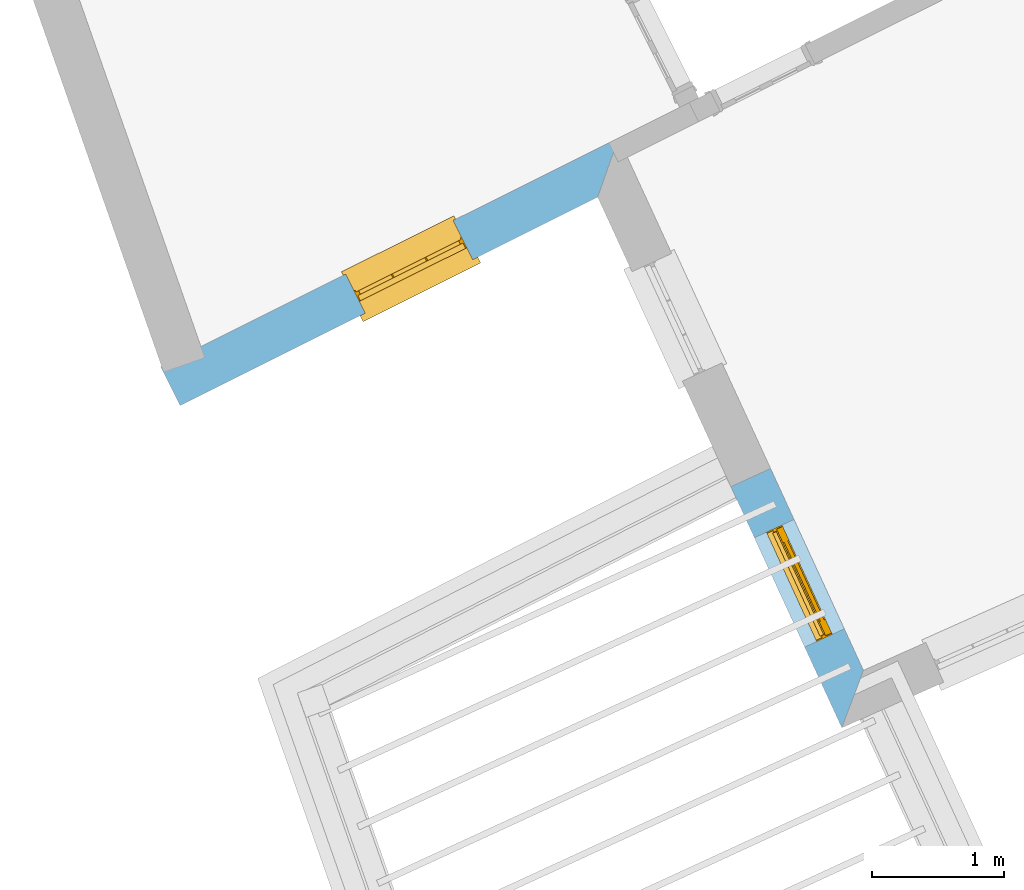
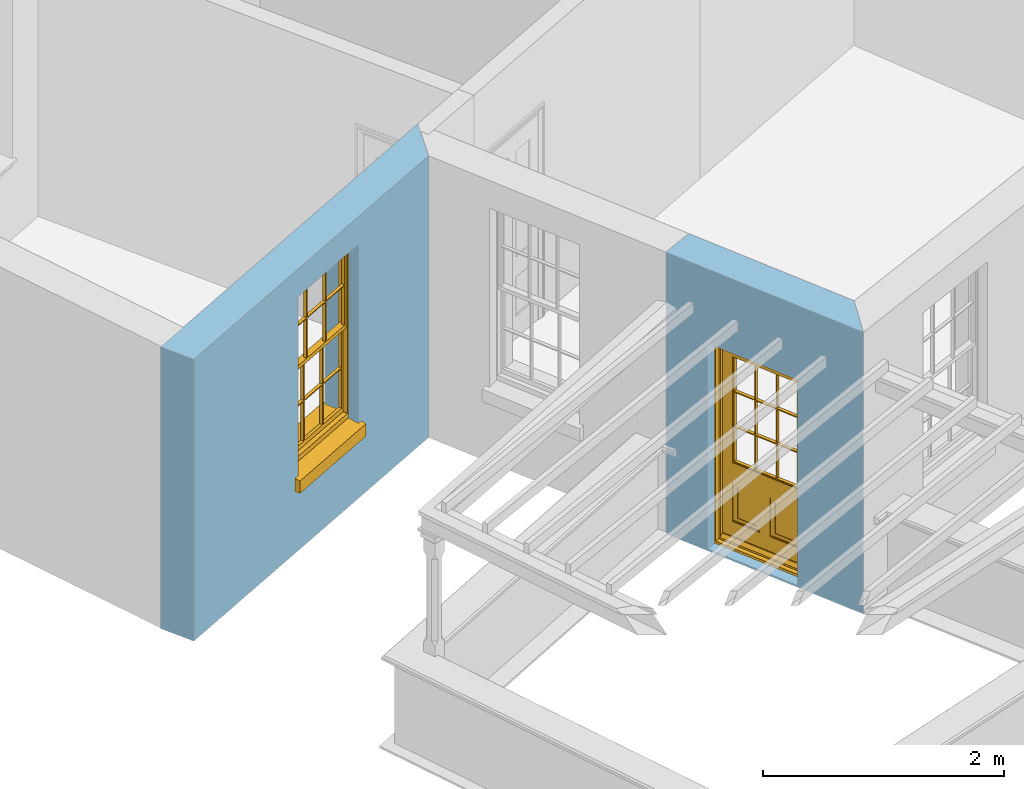
# One storey, part 2 of 9: 1 door, 1 window, 2 openings, plus 2 elements that do not belong to this part.
"""IFC2X3 building model written with IfcOpenShell, lengths in metres."""

from ifc_helpers import new_model, si_unit, frame, origin, place, context, subcontext, project, spatial, polyline, outline, extrude, faceted_brep, material, layer, layer_set, layer_usage, element, fill, save


model = new_model("IFC2X3")

# Units and contexts
model_context = context("Model", 3, world=origin())
body_context = subcontext(model_context, "Body", "Model", "MODEL_VIEW")
ifc_project = project(units=[si_unit("PLANEANGLEUNIT", "RADIAN"), si_unit("MASSUNIT", "GRAM", prefix="KILO"), si_unit("FORCEUNIT", "NEWTON", prefix="KILO"), si_unit("LENGTHUNIT", "METRE")], contexts=[model_context])

# Site, building, storey
site_placement = place(None, origin())
site = spatial("IfcSite", under=ifc_project, at=site_placement, CompositionType="ELEMENT")
building_placement = place(None, origin())
building = spatial("IfcBuilding", under=site, at=building_placement, Name="Building plot-8", CompositionType="ELEMENT")
storey_placement = place(None, frame((0.0, 0.0, 3.45)))
storey = spatial("IfcBuildingStorey", under=building, at=storey_placement, Name="Floor 1", CompositionType="ELEMENT", Elevation=3.45)

# Wall, opening, window
ifc_material = material(Name="Masonry")
ifc_layer = layer(ifc_material, 0.33, ventilated=False)
ifc_layer_set = layer_set([ifc_layer], Name="My Wall")
ifc_layer_usage = layer_usage(ifc_layer_set, "AXIS2", "NEGATIVE", 0.08)
wall_1_placement = place(storey_placement, origin())
wall_1 = element("IfcWallStandardCase", 1, at=wall_1_placement, inside=storey, material=ifc_layer_usage, Name="exterior", context=body_context, shape_type="SweptSolid", body=[
    extrude(outline(polyline([(20.3764991877736, 11.4305323605085), (20.5239010288899, 11.1352821323367), (23.6804146792413, 12.7111519511387), (23.8378385127795, 13.1585845025615), (20.3764991877736, 11.4305323605085)])), origin(), (0.0, 0.0, 1.0), 2.85),
])
opening_1_placement = place(storey_placement, frame((0.0, 0.0, 0.75)))
opening_1 = element("IfcOpeningElement", 2, at=opening_1_placement, cuts=wall_1, Name="Opening", ObjectType="Opening", context=body_context, shape_type="SweptSolid", body=[
    extrude(outline(polyline([(21.9223718965962, 11.8334600200347), (22.7365467682216, 12.2399317637189), (22.5891449271054, 12.5351819918908), (21.7749700554799, 12.1287102482065), (21.9223718965962, 11.8334600200347)])), origin(), (0.0, 0.0, 1.0), 1.82),
])
window_placement = place(storey_placement, frame((21.8107038351445, 12.0571344353164, 0.75), z_axis=(0.0, 0.0, 1.0), x_axis=(0.814174871625426, 0.406471743684262, 0.0)))
window = element("IfcWindow", 3, at=window_placement, inside=storey, Name="bedroom outside window", OverallHeight=1.82, OverallWidth=0.91, context=body_context, shape_type="Brep", held_by="IfcProductRepresentation", body=[
    faceted_brep([(0.033125, -0.105, 0.975209), (0.01, -0.105, 0.975209), (0.033125, -0.105, 1.376042), (0.876875, -0.105, 0.975209), (0.876875, -0.105, 1.376042), (0.9, -0.105, 0.975209), (0.876875, -0.105, 1.386042), (0.876875, -0.105, 1.786875), (0.9, -0.105, 1.81), (0.033125, -0.105, 1.786875), (0.033125, -0.105, 1.386042), (0.01, -0.105, 1.81), (0.876875, -0.135, 1.376042), (0.876875, -0.135, 0.975209), (0.9, -0.135, 0.937083), (0.033125, -0.135, 1.786875), (0.01, -0.135, 1.81), (0.033125, -0.135, 1.386042), (0.01, -0.135, 0.937083), (0.033125, -0.135, 0.975209), (0.033125, -0.135, 1.376042), (0.876875, -0.135, 1.786875), (0.876875, -0.135, 1.386042), (0.9, -0.135, 1.81), (0.033125, -0.105, 0.937083), (0.01, -0.105, 0.937083), (0.033125, -0.105, 0.53625), (0.876875, -0.105, 0.937083), (0.876875, -0.105, 0.53625), (0.9, -0.105, 0.937083), (0.876875, -0.105, 0.52625), (0.876875, -0.105, 0.125417), (0.9, -0.105, 0.077167), (0.033125, -0.105, 0.125417), (0.033125, -0.105, 0.52625), (0.01, -0.105, 0.077167), (-0.0425, -0.25, 0.01), (-0.0425, -0.3, 0.001667), (0.0, -0.25, 0.01), (0.9525, -0.25, 0.01), (0.91, -0.25, 0.01), (0.9525, -0.3, 0.001667), (-0.02, 0.08, 0.077167), (0.0, 0.08, 0.077167), (-0.02, 0.11, 0.077167), (0.0, -0.06, 0.077167), (0.01, -0.06, 0.077167), (0.91, -0.06, 0.077167), (0.91, 0.08, 0.077167), (0.9, -0.06, 0.077167), (0.93, 0.08, 0.077167), (0.93, 0.11, 0.077167), (0.01, -0.075, 0.975209), (0.9, -0.075, 0.975209), (0.876875, -0.075, 0.125417), (0.876875, -0.075, 0.52625), (0.9, -0.075, 0.077167), (0.876875, -0.075, 0.53625), (0.876875, -0.075, 0.937083), (0.033125, -0.075, 0.125417), (0.01, -0.075, 0.077167), (0.033125, -0.075, 0.52625), (0.033125, -0.075, 0.937083), (0.033125, -0.075, 0.53625), (-0.02, 0.08, 0.052167), (-0.02, 0.11, 0.052167), (0.93, 0.11, 0.052167), (0.93, 0.08, 0.052167), (0.91, 0.08, 0.052167), (0.0, 0.08, 0.052167), (0.91, -0.15, 0.026667), (0.0, -0.15, 0.026667), (-0.0425, -0.3, -0.123333), (0.9525, -0.3, -0.123333), (-0.0425, -0.25, -0.123333), (0.9525, -0.25, -0.123333), (0.01, -0.06, 1.81), (0.9, -0.06, 1.81), (0.0, -0.06, 1.82), (0.91, -0.06, 1.82), (0.01, -0.15, 0.077167), (0.9, -0.15, 0.077167), (0.592292, -0.105, 0.125417), (0.592292, -0.075, 0.125417), (0.317708, -0.075, 0.125417), (0.317708, -0.105, 0.125417), (0.592292, -0.105, 0.53625), (0.317708, -0.105, 0.53625), (0.317708, -0.105, 0.52625), (0.592292, -0.105, 0.52625), (0.592292, -0.075, 0.53625), (0.317708, -0.075, 0.53625), (0.592292, -0.135, 1.386042), (0.592292, -0.105, 1.386042), (0.317708, -0.105, 1.386042), (0.317708, -0.135, 1.386042), (0.317708, -0.135, 1.376042), (0.592292, -0.135, 1.376042), (0.317708, -0.105, 1.376042), (0.592292, -0.105, 1.376042), (0.602292, -0.135, 1.376042), (0.592292, -0.135, 0.975209), (0.602292, -0.135, 0.975209), (0.602292, -0.105, 0.975209), (0.592292, -0.105, 0.975209), (0.602292, -0.105, 1.376042), (0.602292, -0.075, 0.53625), (0.602292, -0.105, 0.53625), (0.317708, -0.075, 0.52625), (0.307708, -0.075, 0.125417), (0.307708, -0.075, 0.52625), (0.602292, -0.075, 0.52625), (0.602292, -0.075, 0.125417), (0.592292, -0.075, 0.52625), (0.307708, -0.075, 0.53625), (0.317708, -0.075, 0.937083), (0.307708, -0.075, 0.937083), (0.602292, -0.075, 0.937083), (0.592292, -0.075, 0.937083), (0.307708, -0.105, 0.52625), (0.307708, -0.105, 0.125417), (0.307708, -0.105, 0.53625), (0.307708, -0.105, 0.937083), (0.592292, -0.105, 0.937083), (0.317708, -0.105, 0.937083), (0.602292, -0.105, 0.937083), (0.602292, -0.105, 0.52625), (0.602292, -0.105, 0.125417), (0.307708, -0.135, 1.386042), (0.307708, -0.135, 1.376042), (0.307708, -0.135, 0.975209), (0.317708, -0.135, 0.975209), (0.317708, -0.135, 1.786875), (0.307708, -0.135, 1.786875), (0.602292, -0.135, 1.786875), (0.592292, -0.135, 1.786875), (0.602292, -0.135, 1.386042), (0.602292, -0.105, 1.386042), (0.307708, -0.105, 1.386042), (0.307708, -0.105, 1.786875), (0.317708, -0.105, 1.786875), (0.592292, -0.105, 1.786875), (0.602292, -0.105, 1.786875), (0.307708, -0.105, 1.376042), (0.317708, -0.105, 0.975209), (0.307708, -0.105, 0.975209), (0.91, -0.15, 1.82), (0.9, -0.15, 1.81), (0.01, -0.15, 1.81), (0.0, -0.15, 1.82), (0.91, -0.25, 0.0), (0.0, -0.25, 0.0), (0.91, 0.08, 0.0), (0.0, 0.08, 0.0)], [[[0, 1, 2]], [[3, 4, 5]], [[6, 7, 8]], [[9, 10, 11]], [[12, 13, 14]], [[15, 16, 17]], [[18, 19, 20]], [[21, 22, 23]], [[24, 25, 26]], [[27, 28, 29]], [[30, 31, 32]], [[33, 34, 35]], [[14, 27, 29]], [[25, 24, 18]], [[36, 37, 38]], [[39, 40, 41]], [[42, 43, 44]], [[45, 46, 43]], [[47, 48, 49]], [[50, 51, 48]], [[1, 0, 52]], [[5, 53, 3]], [[54, 55, 56]], [[57, 58, 53]], [[59, 60, 61]], [[62, 63, 52]], [[48, 43, 46, 49]], [[51, 44, 43, 48]], [[64, 42, 44, 65]], [[65, 44, 51, 66]], [[66, 51, 50, 67]], [[65, 66, 68, 69]], [[60, 56, 49, 46]], [[70, 71, 38, 40]], [[37, 41, 40, 38]], [[37, 72, 73, 41]], [[74, 75, 73, 72]], [[8, 11, 76, 77]], [[76, 78, 79, 77]], [[32, 35, 80, 81]], [[81, 80, 71, 70]], [[82, 83, 84, 85]], [[86, 87, 88, 89]], [[86, 90, 91, 87]], [[92, 93, 94, 95]], [[92, 95, 96, 97]], [[96, 98, 99, 97]], [[100, 97, 101, 102]], [[103, 104, 99, 105]], [[97, 99, 104, 101]], [[102, 103, 105, 100]], [[28, 57, 106, 107]], [[108, 84, 109, 110]], [[111, 112, 83, 113]], [[114, 110, 61, 63]], [[90, 113, 108, 91]], [[115, 91, 114, 116]], [[117, 106, 90, 118]], [[111, 106, 57, 55]], [[119, 110, 109, 120]], [[34, 61, 110, 119]], [[89, 113, 83, 82]], [[88, 108, 113, 89]], [[85, 84, 108, 88]], [[121, 114, 63, 26]], [[122, 116, 114, 121]], [[123, 118, 90, 86]], [[87, 91, 115, 124]], [[107, 106, 117, 125]], [[126, 111, 55, 30]], [[127, 112, 111, 126]], [[126, 30, 28, 107]], [[88, 119, 120, 85]], [[126, 89, 82, 127]], [[125, 123, 86, 107]], [[121, 26, 34, 119]], [[124, 122, 121, 87]], [[128, 17, 20, 129]], [[96, 129, 130, 131]], [[132, 133, 128, 95]], [[134, 135, 92, 136]], [[100, 12, 22, 136]], [[137, 6, 4, 105]], [[94, 138, 139, 140]], [[137, 93, 141, 142]], [[99, 98, 94, 93]], [[143, 2, 10, 138]], [[144, 145, 143, 98]], [[129, 143, 145, 130]], [[20, 2, 143, 129]], [[131, 144, 98, 96]], [[128, 138, 10, 17]], [[133, 139, 138, 128]], [[135, 141, 93, 92]], [[95, 94, 140, 132]], [[22, 6, 137, 136]], [[136, 137, 142, 134]], [[100, 105, 4, 12]], [[107, 86, 89, 126]], [[106, 111, 113, 90]], [[91, 108, 110, 114]], [[87, 121, 119, 88]], [[97, 100, 136, 92]], [[129, 96, 95, 128]], [[98, 143, 138, 94]], [[105, 99, 93, 137]], [[131, 101, 104, 144]], [[124, 115, 118, 123]], [[132, 140, 141, 135]], [[120, 109, 59, 33]], [[15, 9, 139, 133]], [[134, 142, 7, 21]], [[31, 54, 112, 127]], [[36, 74, 72, 37]], [[39, 41, 73, 75]], [[18, 14, 101, 131]], [[23, 16, 132, 135]], [[83, 56, 60, 84]], [[52, 53, 118, 115]], [[53, 52, 144, 104]], [[11, 8, 141, 140]], [[14, 18, 124, 123]], [[2, 1, 11, 10]], [[8, 5, 4, 6]], [[57, 53, 56, 55]], [[60, 52, 63, 61]], [[26, 25, 35, 34]], [[32, 29, 28, 30]], [[14, 23, 22, 12]], [[18, 20, 17, 16]], [[19, 0, 2, 20]], [[17, 10, 9, 15]], [[12, 4, 3, 13]], [[21, 7, 6, 22]], [[27, 58, 57, 28]], [[30, 55, 54, 31]], [[33, 59, 61, 34]], [[26, 63, 62, 24]], [[5, 8, 77, 53]], [[76, 11, 1, 52]], [[46, 45, 78, 76]], [[49, 77, 79, 47]], [[70, 146, 147, 81]], [[71, 80, 148, 149]], [[19, 130, 145, 0]], [[102, 13, 3, 103]], [[116, 122, 24, 62]], [[29, 32, 81, 14]], [[80, 35, 25, 18]], [[60, 46, 76, 52]], [[77, 49, 56, 53]], [[23, 14, 81, 147]], [[16, 148, 80, 18]], [[35, 85, 120]], [[120, 33, 35]], [[127, 82, 32]], [[32, 31, 127]], [[32, 82, 85, 35]], [[102, 101, 14]], [[14, 13, 102]], [[18, 131, 130]], [[130, 19, 18]], [[134, 21, 23]], [[23, 135, 134]], [[16, 15, 133]], [[133, 132, 16]], [[11, 140, 139]], [[139, 9, 11]], [[142, 141, 8]], [[8, 7, 142]], [[23, 147, 148, 16]], [[146, 149, 148, 147]], [[52, 115, 116]], [[116, 62, 52]], [[118, 53, 117]], [[58, 117, 53]], [[27, 125, 117, 58]], [[56, 83, 112]], [[112, 54, 56]], [[109, 84, 60]], [[60, 59, 109]], [[125, 27, 14]], [[14, 123, 125]], [[122, 124, 18]], [[18, 24, 122]], [[145, 144, 52]], [[52, 0, 145]], [[103, 3, 53]], [[53, 104, 103]], [[79, 78, 149, 146]], [[78, 45, 71, 149]], [[146, 70, 47, 79]], [[150, 75, 74, 151]], [[68, 66, 67]], [[48, 68, 67, 50]], [[69, 64, 65]], [[42, 64, 69, 43]], [[69, 68, 152, 153]], [[70, 68, 48, 47]], [[150, 152, 68, 70]], [[43, 69, 71, 45]], [[69, 153, 151, 71]], [[152, 150, 151, 153]], [[38, 151, 74, 36]], [[71, 151, 38]], [[39, 75, 150, 40]], [[40, 150, 70]]]),
])
fill(opening_1, window)

# Wall, opening, door
wall_2_placement = place(storey_placement, origin())
wall_2 = element("IfcWallStandardCase", 4, at=wall_2_placement, inside=storey, material=ifc_layer_usage, Name="exterior", context=body_context, shape_type="SweptSolid", body=[
    extrude(outline(polyline([(24.9867751738983, 10.6608454725049), (24.6869722630542, 10.5229389293337), (25.5254164354395, 8.70019725456561), (25.6887883842839, 9.13469885839309), (24.9867751738983, 10.6608454725049)])), origin(), (0.0, 0.0, 1.0), 2.85),
])
opening_2_placement = place(storey_placement, frame((0.0, 0.0, 0.02)))
opening_2 = element("IfcOpeningElement", 5, at=opening_2_placement, cuts=wall_2, Name="Opening", ObjectType="Opening", context=body_context, shape_type="SweptSolid", body=[
    extrude(outline(polyline([(24.86437208442, 10.1372793253317), (25.24465982468, 9.31055008633751), (25.544462735524, 9.44845662950871), (25.1641749952641, 10.2751858685029), (24.86437208442, 10.1372793253317)])), origin(), (0.0, 0.0, 1.0), 2.08),
])
door_placement = place(storey_placement, frame((25.0914955017261, 10.2417539792493, 0.02), z_axis=(0.0, 0.0, 1.0), x_axis=(0.38028774025997, -0.826729238994224, 0.0)))
door = element("IfcDoor", 6, at=door_placement, inside=storey, Name="living outside door", OverallHeight=2.08, OverallWidth=0.91, context=body_context, shape_type="Brep", held_by="IfcProductRepresentation", body=[
    faceted_brep([(0.545, -0.055, 0.265), (0.745, -0.055, 0.265), (0.745, -0.05, 0.265), (0.545, -0.05, 0.265), (0.745, -0.05, 0.58), (0.545, -0.05, 0.58), (0.545, -0.055, 0.58), (0.515, -0.06, 0.235), (0.775, -0.06, 0.235), (0.745, -0.055, 0.58), (0.515, -0.06, 0.61), (0.515, -0.065, 0.235), (0.775, -0.065, 0.235), (0.775, -0.06, 0.61), (0.515, -0.065, 0.61), (0.785, -0.065, 0.225), (0.505, -0.065, 0.225), (0.775, -0.065, 0.61), (0.505, -0.065, 0.62), (0.785, -0.065, 0.62), (0.505, -0.07, 0.225), (0.785, -0.07, 0.225), (0.505, -0.07, 0.62), (0.785, -0.07, 0.62), (0.883, -0.07, 0.075), (0.898, -0.07, 0.075), (0.405, -0.07, 0.62), (0.405, -0.07, 0.225), (0.027, -0.07, 0.075), (0.785, -0.07, 0.82), (0.125, -0.07, 0.82), (0.405, -0.065, 0.62), (0.405, -0.065, 0.225), (0.898, -0.07, 2.068), (0.027, -0.08, 0.075), (0.883, -0.08, 0.075), (0.125, -0.07, 0.225), (0.012, -0.07, 0.075), (0.785, -0.06, 0.82), (0.125, -0.06, 0.82), (0.125, -0.07, 0.62), (0.125, -0.065, 0.62), (0.395, -0.065, 0.61), (0.395, -0.065, 0.235), (0.125, -0.065, 0.225), (0.785, -0.07, 1.895), (0.027, -0.11, 0.045), (0.883, -0.11, 0.045), (0.558333, -0.06, 0.83), (0.351667, -0.06, 0.83), (0.125, -0.07, 1.895), (0.125, -0.06, 1.895), (0.785, -0.06, 1.895), (0.012, -0.07, 2.068), (0.135, -0.065, 0.61), (0.395, -0.06, 0.61), (0.395, -0.06, 0.235), (0.135, -0.065, 0.235), (0.027, -0.11, 0.027), (0.883, -0.11, 0.027), (0.568333, -0.06, 0.83), (0.558333, -0.03, 0.83), (0.351667, -0.03, 0.83), (0.341667, -0.06, 0.83), (0.135, -0.06, 1.185), (0.135, -0.06, 1.53), (0.775, -0.06, 1.53), (0.775, -0.06, 1.185), (0.135, -0.06, 0.61), (0.365, -0.055, 0.58), (0.365, -0.055, 0.265), (0.135, -0.06, 0.235), (0.568333, -0.06, 1.175), (0.558333, -0.06, 1.175), (0.775, -0.06, 0.83), (0.558333, -0.03, 1.175), (0.785, -0.03, 0.82), (0.125, -0.03, 0.82), (0.351667, -0.03, 1.175), (0.351667, -0.06, 1.175), (0.341667, -0.06, 1.175), (0.135, -0.06, 0.83), (0.135, -0.06, 1.175), (0.135, -0.03, 1.185), (0.135, -0.03, 1.53), (0.135, -0.06, 1.54), (0.351667, -0.06, 1.885), (0.558333, -0.06, 1.885), (0.775, -0.03, 1.53), (0.775, -0.03, 1.185), (0.775, -0.06, 1.175), (0.775, -0.06, 1.54), (0.165, -0.055, 0.58), (0.365, -0.05, 0.58), (0.365, -0.05, 0.265), (0.165, -0.055, 0.265), (0.568333, -0.03, 0.83), (0.568333, -0.03, 1.175), (0.568333, -0.06, 1.185), (0.558333, -0.06, 1.185), (0.775, -0.03, 0.83), (0.785, -0.02, 0.82), (0.125, -0.02, 0.82), (0.341667, -0.03, 0.83), (0.341667, -0.03, 1.175), (0.351667, -0.06, 1.185), (0.341667, -0.06, 1.185), (0.135, -0.03, 0.83), (0.341667, -0.03, 1.185), (0.125, -0.03, 1.895), (0.341667, -0.03, 1.53), (0.341667, -0.06, 1.53), (0.135, -0.06, 1.885), (0.341667, -0.06, 1.54), (0.341667, -0.06, 1.885), (0.558333, -0.03, 1.885), (0.351667, -0.03, 1.885), (0.568333, -0.06, 1.885), (0.785, -0.03, 1.895), (0.568333, -0.03, 1.185), (0.568333, -0.06, 1.53), (0.568333, -0.03, 1.53), (0.568333, -0.06, 1.54), (0.775, -0.06, 1.885), (0.165, -0.05, 0.58), (0.165, -0.05, 0.265), (0.775, -0.03, 1.175), (0.558333, -0.06, 1.53), (0.351667, -0.03, 1.185), (0.558333, -0.03, 1.185), (0.505, -0.02, 0.62), (0.405, -0.02, 0.62), (0.125, -0.02, 1.895), (0.785, -0.02, 1.895), (0.351667, -0.06, 1.53), (0.135, -0.03, 1.175), (0.135, -0.03, 1.54), (0.341667, -0.03, 1.54), (0.135, -0.03, 1.885), (0.351667, -0.06, 1.54), (0.558333, -0.03, 1.54), (0.558333, -0.06, 1.54), (0.351667, -0.03, 1.54), (0.775, -0.03, 1.54), (0.568333, -0.03, 1.54), (0.775, -0.03, 1.885), (0.558333, -0.03, 1.53), (0.405, -0.02, 0.225), (0.505, -0.02, 0.225), (0.125, -0.02, 0.62), (0.785, -0.02, 0.62), (0.012, -0.02, 2.068), (0.898, -0.02, 2.068), (0.351667, -0.03, 1.53), (0.341667, -0.03, 1.885), (0.568333, -0.03, 1.885), (0.405, -0.025, 0.225), (0.405, -0.025, 0.62), (0.505, -0.025, 0.62), (0.505, -0.025, 0.225), (0.898, -0.02, 0.027), (0.012, -0.02, 0.027), (0.125, -0.025, 0.62), (0.785, -0.025, 0.62), (0.395, -0.025, 0.235), (0.395, -0.025, 0.61), (0.125, -0.02, 0.225), (0.125, -0.025, 0.225), (0.515, -0.025, 0.61), (0.515, -0.025, 0.235), (0.785, -0.02, 0.225), (0.785, -0.025, 0.225), (0.135, -0.025, 0.61), (0.775, -0.025, 0.61), (0.135, -0.025, 0.235), (0.395, -0.03, 0.235), (0.395, -0.03, 0.61), (0.515, -0.03, 0.61), (0.515, -0.03, 0.235), (0.775, -0.025, 0.235), (0.135, -0.03, 0.61), (0.775, -0.03, 0.61), (0.135, -0.03, 0.235), (0.365, -0.035, 0.265), (0.365, -0.035, 0.58), (0.545, -0.035, 0.58), (0.545, -0.035, 0.265), (0.775, -0.03, 0.235), (0.165, -0.035, 0.58), (0.745, -0.035, 0.58), (0.165, -0.035, 0.265), (0.365, -0.04, 0.58), (0.365, -0.04, 0.265), (0.545, -0.04, 0.58), (0.545, -0.04, 0.265), (0.745, -0.035, 0.265), (0.165, -0.04, 0.58), (0.745, -0.04, 0.58), (0.165, -0.04, 0.265), (0.745, -0.04, 0.265), (0.885, -0.072, 0.025), (0.025, -0.072, 0.025), (0.025, -0.1, 0.025), (0.885, -0.1, 0.025), (0.9, -0.02, 0.025), (0.01, -0.02, 0.025), (0.9, -0.072, 0.025), (0.91, -0.02, 0.0), (0.0, -0.02, 0.0), (0.01, -0.072, 0.025), (0.9, -0.072, 2.07), (0.9, -0.02, 2.07), (0.885, -0.072, 2.055), (0.91, -0.02, 2.08), (0.01, -0.02, 2.07), (0.0, -0.02, 2.08), (0.01, -0.072, 2.07), (0.025, -0.072, 2.055), (0.0, -0.15, 2.08), (0.91, -0.15, 2.08), (0.01, -0.15, 2.07), (0.9, -0.15, 2.07), (0.01, -0.1, 2.07), (0.9, -0.1, 2.07), (0.0, -0.15, 0.0), (0.91, -0.15, 0.0), (0.01, -0.15, 0.025), (0.9, -0.15, 0.025), (0.01, -0.1, 0.025), (0.025, -0.1, 2.055), (0.9, -0.1, 0.025), (0.885, -0.1, 2.055), (0.898, -0.07, 0.027), (0.012, -0.07, 0.027), (0.883, -0.07, 0.027), (0.027, -0.07, 0.027)], [[[0, 1, 2, 3]], [[2, 4, 5, 3]], [[0, 3, 5, 6]], [[1, 0, 7, 8]], [[9, 4, 2, 1]], [[9, 6, 5, 4]], [[0, 6, 10, 7]], [[8, 7, 11, 12]], [[8, 13, 9, 1]], [[13, 10, 6, 9]], [[7, 10, 14, 11]], [[15, 12, 11, 16]], [[12, 17, 13, 8]], [[17, 14, 10, 13]], [[18, 16, 11, 14]], [[15, 19, 17, 12]], [[15, 16, 20, 21]], [[14, 17, 19, 18]], [[16, 18, 22, 20]], [[21, 23, 19, 15]], [[24, 25, 21, 20]], [[23, 22, 18, 19]], [[20, 22, 26, 27]], [[23, 21, 25]], [[28, 24, 20, 27]], [[22, 23, 29]], [[29, 30, 26, 22]], [[27, 26, 31, 32]], [[23, 25, 33, 29]], [[34, 35, 24, 28]], [[28, 27, 36, 37]], [[38, 39, 30, 29]], [[26, 30, 40]], [[26, 40, 41, 31]], [[42, 43, 32, 31]], [[32, 44, 36, 27]], [[33, 45, 29]], [[46, 47, 35, 34]], [[36, 40, 37]], [[39, 38, 48, 49]], [[50, 30, 39, 51]], [[29, 45, 52, 38]], [[53, 37, 40, 30]], [[44, 41, 40, 36]], [[31, 41, 54, 42]], [[43, 42, 55, 56]], [[57, 44, 32, 43]], [[50, 45, 33, 53]], [[47, 46, 58, 59]], [[60, 48, 38]], [[49, 48, 61, 62]], [[49, 63, 39]], [[50, 53, 30]], [[51, 39, 64, 65]], [[45, 50, 51, 52]], [[66, 67, 38, 52]], [[57, 54, 41, 44]], [[42, 54, 68, 55]], [[56, 55, 69, 70]], [[56, 71, 57, 43]], [[60, 72, 73, 48]], [[60, 38, 74]], [[48, 73, 75, 61]], [[76, 77, 62, 61]], [[62, 78, 79, 49]], [[49, 79, 80, 63]], [[63, 81, 39]], [[82, 64, 39]], [[65, 64, 83, 84]], [[85, 51, 65]], [[52, 51, 86, 87]], [[88, 89, 67, 66]], [[90, 38, 67]], [[91, 66, 52]], [[71, 68, 54, 57]], [[55, 68, 92, 69]], [[69, 93, 94, 70]], [[70, 95, 71, 56]], [[96, 97, 72, 60]], [[73, 72, 98, 99]], [[74, 38, 90]], [[100, 96, 60, 74]], [[75, 73, 79, 78]], [[61, 75, 97, 96]], [[101, 102, 77, 76]], [[77, 103, 62]], [[96, 76, 61]], [[103, 104, 78, 62]], [[80, 79, 105, 106]], [[63, 80, 104, 103]], [[81, 63, 103, 107]], [[81, 82, 39]], [[106, 64, 82, 80]], [[106, 108, 83, 64]], [[84, 83, 77, 109]], [[110, 111, 65, 84]], [[112, 51, 85]], [[113, 85, 65, 111]], [[114, 86, 51]], [[115, 87, 86, 116]], [[117, 52, 87]], [[118, 76, 89, 88]], [[119, 98, 67, 89]], [[120, 121, 88, 66]], [[67, 98, 72, 90]], [[91, 122, 120, 66]], [[91, 52, 123]], [[95, 92, 68, 71]], [[69, 92, 124, 93]], [[94, 93, 124, 125]], [[94, 125, 95, 70]], [[72, 97, 126, 90]], [[127, 99, 98, 120]], [[99, 105, 79, 73]], [[74, 90, 126, 100]], [[96, 100, 76]], [[128, 129, 75, 78]], [[97, 75, 129, 119]], [[130, 131, 102, 101]], [[109, 77, 102, 132]], [[133, 101, 76, 118]], [[77, 107, 103]], [[78, 104, 108, 128]], [[111, 106, 105, 134]], [[104, 80, 82, 135]], [[107, 135, 82, 81]], [[110, 108, 106, 111]], [[104, 135, 83, 108]], [[83, 135, 77]], [[136, 84, 109]], [[110, 84, 136, 137]], [[114, 51, 112]], [[85, 136, 138, 112]], [[113, 137, 136, 85]], [[111, 134, 139, 113]], [[86, 114, 113, 139]], [[140, 141, 87, 115]], [[139, 142, 116, 86]], [[109, 118, 115, 116]], [[117, 123, 52]], [[117, 87, 141, 122]], [[126, 89, 76]], [[143, 118, 88]], [[120, 98, 119, 121]], [[119, 89, 126, 97]], [[144, 143, 88, 121]], [[144, 122, 91, 143]], [[127, 120, 122, 141]], [[143, 91, 123, 145]], [[124, 92, 95, 125]], [[146, 129, 99, 127]], [[99, 129, 128, 105]], [[100, 126, 76]], [[121, 119, 129, 146]], [[147, 131, 130, 148]], [[131, 149, 102]], [[130, 101, 150]], [[102, 151, 132]], [[118, 109, 132, 133]], [[101, 133, 152]], [[107, 77, 135]], [[153, 128, 108, 110]], [[134, 105, 128, 153]], [[109, 138, 136]], [[153, 110, 137, 142]], [[154, 114, 112, 138]], [[137, 113, 114, 154]], [[141, 139, 134, 127]], [[141, 140, 142, 139]], [[144, 140, 115, 155]], [[142, 137, 154, 116]], [[155, 115, 118]], [[116, 154, 109]], [[117, 155, 145, 123]], [[122, 144, 155, 117]], [[143, 145, 118]], [[121, 146, 140, 144]], [[146, 127, 134, 153]], [[156, 157, 131, 147]], [[148, 130, 158, 159]], [[148, 160, 161, 147]], [[157, 162, 149, 131]], [[161, 151, 102, 149]], [[101, 152, 160, 150]], [[163, 158, 130, 150]], [[151, 152, 133, 132]], [[154, 138, 109]], [[142, 140, 146, 153]], [[145, 155, 118]], [[157, 156, 164, 165]], [[147, 166, 167, 156]], [[168, 169, 159, 158]], [[170, 148, 159, 171]], [[148, 170, 160]], [[166, 147, 161]], [[172, 162, 157, 165]], [[166, 149, 162, 167]], [[166, 161, 149]], [[150, 160, 170]], [[163, 173, 168, 158]], [[171, 163, 150, 170]], [[174, 164, 156, 167]], [[175, 176, 165, 164]], [[169, 168, 177, 178]], [[171, 159, 169, 179]], [[167, 162, 172, 174]], [[176, 180, 172, 165]], [[179, 173, 163, 171]], [[181, 177, 168, 173]], [[164, 174, 182, 175]], [[183, 184, 176, 175]], [[178, 177, 185, 186]], [[179, 169, 178, 187]], [[174, 172, 180, 182]], [[184, 188, 180, 176]], [[187, 181, 173, 179]], [[189, 185, 177, 181]], [[175, 182, 190, 183]], [[191, 184, 183, 192]], [[185, 193, 194, 186]], [[187, 178, 186, 195]], [[182, 180, 188, 190]], [[191, 196, 188, 184]], [[195, 189, 181, 187]], [[197, 193, 185, 189]], [[183, 190, 198, 192]], [[198, 196, 191, 192]], [[194, 193, 197, 199]], [[195, 186, 194, 199]], [[188, 196, 198, 190]], [[197, 189, 195, 199]], [[200, 201, 202, 203]], [[201, 200, 204, 205]], [[206, 204, 200]], [[204, 207, 208, 205]], [[209, 201, 205]], [[210, 211, 204, 206]], [[206, 200, 212, 210]], [[211, 213, 207, 204]], [[214, 205, 208, 215]], [[216, 217, 201, 209]], [[205, 214, 216, 209]], [[216, 214, 211, 210]], [[210, 212, 217, 216]], [[214, 215, 213, 211]], [[218, 219, 213, 215]], [[219, 218, 220, 221]], [[221, 220, 222, 223]], [[215, 208, 224, 218]], [[225, 224, 208, 207]], [[224, 226, 220, 218]], [[224, 225, 227, 226]], [[219, 225, 207, 213]], [[228, 222, 220, 226]], [[219, 221, 227, 225]], [[226, 227, 203, 202]], [[202, 229, 222, 228]], [[228, 226, 202]], [[227, 221, 223, 230]], [[230, 203, 227]], [[217, 229, 202, 201]], [[231, 223, 222, 229]], [[230, 223, 231, 203]], [[231, 229, 217, 212]], [[212, 200, 203, 231]], [[33, 152, 151, 53]], [[25, 160, 152, 33]], [[161, 37, 53, 151]], [[232, 160, 25]], [[161, 233, 37]], [[160, 232, 234]], [[24, 234, 232, 25]], [[233, 161, 235]], [[37, 233, 235, 28]], [[161, 160, 234, 235]], [[35, 47, 234, 24]], [[28, 235, 46, 34]], [[58, 235, 234, 59]], [[59, 234, 47]], [[58, 46, 235]]]),
])
fill(opening_2, door)

save(model, "model.ifc")
